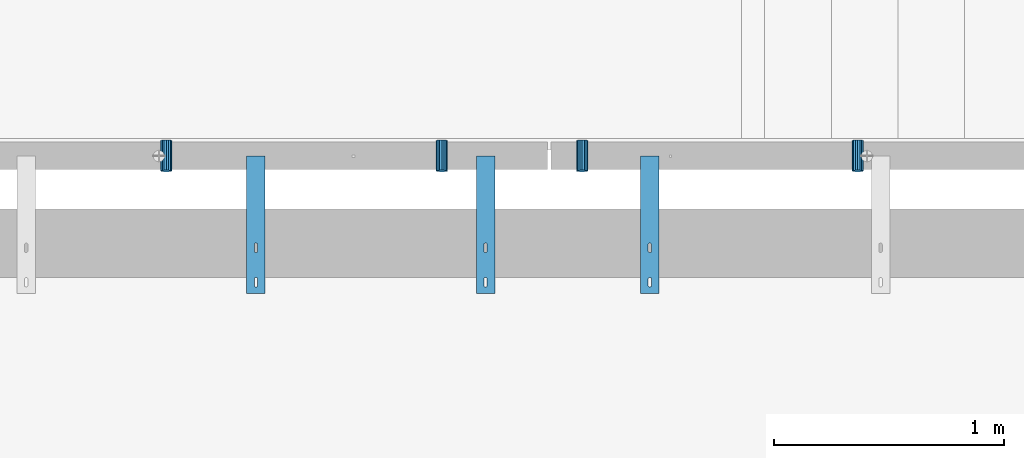
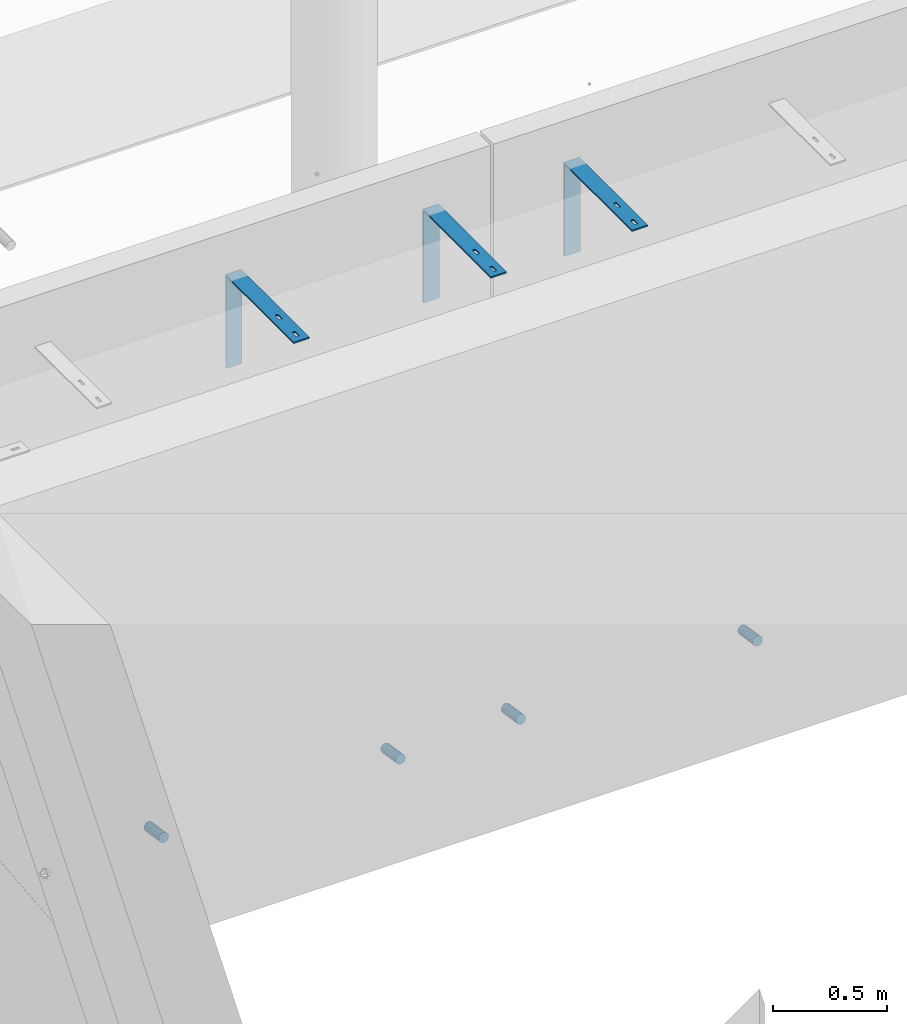
# One storey, part 101 of 264: 7 beams, 8 elements without a shape of their own.
"""IFC2X3 building model written with IfcOpenShell, lengths in millimetres."""

from ifc_helpers import new_model, si_unit, frame, origin_with_axes, place, context, subcontext, project, spatial, faceted_brep, material, type_object, element, aggregate, save


model = new_model("IFC2X3")

# Units and contexts
model_context = context("Model", 3, precision=1e-05, world=origin_with_axes())
body_context = subcontext(model_context, "Body", "Model", "MODEL_VIEW")
ifc_project = project(units=[si_unit("LENGTHUNIT", "METRE", prefix="MILLI"), si_unit("AREAUNIT", "SQUARE_METRE"), si_unit("VOLUMEUNIT", "CUBIC_METRE"), si_unit("MASSUNIT", "GRAM", prefix="KILO"), si_unit("TIMEUNIT", "SECOND"), si_unit("PLANEANGLEUNIT", "RADIAN"), si_unit("SOLIDANGLEUNIT", "STERADIAN"), si_unit("THERMODYNAMICTEMPERATUREUNIT", "DEGREE_CELSIUS"), si_unit("LUMINOUSINTENSITYUNIT", "LUMEN")], contexts=[model_context])

# Site, building, storey
site_placement = place(None, origin_with_axes())
site = spatial("IfcSite", under=ifc_project, at=site_placement, CompositionType="ELEMENT")
building_placement = place(site_placement, origin_with_axes())
building = spatial("IfcBuilding", under=site, at=building_placement, CompositionType="ELEMENT")
storey_placement = place(building_placement, origin_with_axes())
storey = spatial("IfcBuildingStorey", under=building, at=storey_placement, Name="K", CompositionType="ELEMENT", Elevation=0.0)

# Assemblies, beam
assembly_1_placement = place(storey_placement, origin_with_axes())
assembly_1 = element("IfcElementAssembly", 1, at=assembly_1_placement, inside=storey, AssemblyPlace="NOTDEFINED", PredefinedType="REINFORCEMENT_UNIT")
assembly_2_placement = place(assembly_1_placement, origin_with_axes())
assembly_2 = element("IfcElementAssembly", 2, at=assembly_2_placement, Name="Steel Assembly", AssemblyPlace="NOTDEFINED", PredefinedType="NOTDEFINED")
ifc_material_1 = material()
beam_type_1 = type_object("IfcBeamType", Name="D50", PredefinedType="NOTDEFINED")
beam_1_placement = place(assembly_2_placement, frame((12294.9999997536, 20794.388890547, 78614.7172983598), z_axis=(-1.0, 3.00000001838171e-08, 0.0), x_axis=(-5.60000020538061e-08, 0.988691934499859, -0.14996085707585)))
beam_1 = element("IfcBeam", 3, at=beam_1_placement, type_object=beam_type_1, material=ifc_material_1, ObjectType="D50", context=body_context, shape_type="Brep", body=[
    faceted_brep([(0.0, -25.0, 0.0), (-3.63797880709171e-12, -23.0969883127837, -9.56708580912891), (133.368135763521, -23.0969883127691, -9.56708580912709), (133.368135766923, -24.9999999999854, 1.81898940354586e-12), (-3.63797880709171e-12, -17.6776695296576, -17.6776695296649), (133.36813576064, -17.6776695296576, -17.677669529663), (-1.09139364212751e-11, -9.56708580913255, -23.0969883127837), (133.368135758712, -9.567085809118, -23.0969883127818), (-1.09139364212751e-11, 0.0, -25.0), (133.368135758034, 0.0, -25.0), (-1.09139364212751e-11, 9.56708580913255, -23.0969883127837), (133.36813575871, 9.56708580913255, -23.0969883127837), (-3.63797880709171e-12, 17.6776695296576, -17.6776695296649), (133.36813576064, 17.6776695296721, -17.677669529663), (-3.63797880709171e-12, 23.0969883127837, -9.56708580912891), (133.36813576352, 23.0969883127982, -9.56708580912709), (0.0, 25.0, 0.0), (133.368135766925, 25.0000000000146, -1.81898940354586e-12), (7.27595761418343e-12, 23.0969883127837, 9.56708580912891), (133.368135770323, 23.0969883127837, 9.56708580912709), (7.27595761418343e-12, 17.6776695296576, 17.6776695296649), (133.368135773204, 17.6776695296721, 17.6776695296649), (1.45519152283669e-11, 9.56708580913255, 23.0969883127837), (133.368135775132, 9.5670858091471, 23.0969883127837), (1.09139364212751e-11, 0.0, 25.0), (133.368135775807, 1.45519152283669e-11, 25.0), (1.45519152283669e-11, -9.56708580913255, 23.0969883127837), (133.368135775134, -9.56708580910345, 23.0969883127837), (7.27595761418343e-12, -17.6776695296576, 17.6776695296649), (133.368135773204, -17.6776695296721, 17.6776695296649), (7.27595761418343e-12, -23.0969883127837, 9.56708580912891), (133.368135770321, -23.0969883127691, 9.56708580912709)], [[[0, 1, 2, 3]], [[1, 4, 5, 2]], [[4, 6, 7, 5]], [[6, 8, 9, 7]], [[8, 10, 11, 9]], [[10, 12, 13, 11]], [[12, 14, 15, 13]], [[14, 16, 17, 15]], [[16, 18, 19, 17]], [[18, 20, 21, 19]], [[20, 22, 23, 21]], [[22, 24, 25, 23]], [[24, 26, 27, 25]], [[26, 28, 29, 27]], [[28, 30, 31, 29]], [[30, 0, 3, 31]], [[5, 7, 9, 11, 13, 15, 17, 19, 21, 23, 25, 27, 29, 31, 3, 2]], [[30, 28, 26, 24, 22, 20, 18, 16, 14, 12, 10, 8, 6, 4, 1, 0]]]),
])
aggregate(assembly_2, [beam_1])

# Assemblies, beams
assembly_3_placement = place(storey_placement, origin_with_axes())
assembly_3 = element("IfcElementAssembly", 4, at=assembly_3_placement, inside=storey, AssemblyPlace="NOTDEFINED", PredefinedType="REINFORCEMENT_UNIT")
assembly_4_placement = place(assembly_3_placement, origin_with_axes())
assembly_4 = element("IfcElementAssembly", 5, at=assembly_4_placement, Name="Steel Assembly", AssemblyPlace="NOTDEFINED", PredefinedType="NOTDEFINED")
beam_2_placement = place(assembly_4_placement, frame((9284.99999975361, 20794.388890547, 78614.7172983598), z_axis=(-1.0, 3.00000001838171e-08, 0.0), x_axis=(-5.60000020538061e-08, 0.988691934499859, -0.14996085707585)))
beam_2 = element("IfcBeam", 6, at=beam_2_placement, type_object=beam_type_1, material=ifc_material_1, ObjectType="D50", context=body_context, shape_type="Brep", body=[
    faceted_brep([(0.0, -25.0, 0.0), (-3.63797880709171e-12, -23.0969883127837, -9.56708580912891), (133.368135763521, -23.0969883127691, -9.56708580912709), (133.368135766923, -24.9999999999854, 1.81898940354586e-12), (-3.63797880709171e-12, -17.6776695296576, -17.6776695296649), (133.36813576064, -17.6776695296576, -17.677669529663), (-1.09139364212751e-11, -9.56708580913255, -23.0969883127837), (133.368135758712, -9.567085809118, -23.0969883127818), (-1.09139364212751e-11, 0.0, -25.0), (133.368135758034, 0.0, -25.0), (-1.09139364212751e-11, 9.56708580913255, -23.0969883127837), (133.36813575871, 9.56708580913255, -23.0969883127837), (-3.63797880709171e-12, 17.6776695296576, -17.6776695296649), (133.36813576064, 17.6776695296721, -17.677669529663), (-3.63797880709171e-12, 23.0969883127837, -9.56708580912891), (133.36813576352, 23.0969883127982, -9.56708580912709), (0.0, 25.0, 0.0), (133.368135766925, 25.0000000000146, -1.81898940354586e-12), (7.27595761418343e-12, 23.0969883127837, 9.56708580912891), (133.368135770323, 23.0969883127837, 9.56708580912709), (7.27595761418343e-12, 17.6776695296576, 17.6776695296649), (133.368135773204, 17.6776695296721, 17.6776695296649), (1.45519152283669e-11, 9.56708580913255, 23.0969883127837), (133.368135775132, 9.5670858091471, 23.0969883127837), (1.09139364212751e-11, 0.0, 25.0), (133.368135775807, 1.45519152283669e-11, 25.0), (1.45519152283669e-11, -9.56708580913255, 23.0969883127837), (133.368135775134, -9.56708580910345, 23.0969883127837), (7.27595761418343e-12, -17.6776695296576, 17.6776695296649), (133.368135773204, -17.6776695296721, 17.6776695296649), (7.27595761418343e-12, -23.0969883127837, 9.56708580912891), (133.368135770321, -23.0969883127691, 9.56708580912709)], [[[0, 1, 2, 3]], [[1, 4, 5, 2]], [[4, 6, 7, 5]], [[6, 8, 9, 7]], [[8, 10, 11, 9]], [[10, 12, 13, 11]], [[12, 14, 15, 13]], [[14, 16, 17, 15]], [[16, 18, 19, 17]], [[18, 20, 21, 19]], [[20, 22, 23, 21]], [[22, 24, 25, 23]], [[24, 26, 27, 25]], [[26, 28, 29, 27]], [[28, 30, 31, 29]], [[30, 0, 3, 31]], [[5, 7, 9, 11, 13, 15, 17, 19, 21, 23, 25, 27, 29, 31, 3, 2]], [[30, 28, 26, 24, 22, 20, 18, 16, 14, 12, 10, 8, 6, 4, 1, 0]]]),
])
aggregate(assembly_4, [beam_2])
assembly_5_placement = place(assembly_3_placement, origin_with_axes())
assembly_5 = element("IfcElementAssembly", 7, at=assembly_5_placement, Name="Steel Assembly", AssemblyPlace="NOTDEFINED", PredefinedType="NOTDEFINED")
beam_3_placement = place(assembly_5_placement, frame((10484.9999997536, 20794.388890547, 78614.7172983598), z_axis=(-1.0, 3.00000001838171e-08, 0.0), x_axis=(-5.60000020538061e-08, 0.988691934499859, -0.14996085707585)))
beam_3 = element("IfcBeam", 8, at=beam_3_placement, type_object=beam_type_1, material=ifc_material_1, ObjectType="D50", context=body_context, shape_type="Brep", body=[
    faceted_brep([(0.0, -25.0, 0.0), (-3.63797880709171e-12, -23.0969883127837, -9.56708580912891), (133.368135763521, -23.0969883127691, -9.56708580912709), (133.368135766923, -24.9999999999854, 1.81898940354586e-12), (-3.63797880709171e-12, -17.6776695296576, -17.6776695296649), (133.36813576064, -17.6776695296576, -17.677669529663), (-1.09139364212751e-11, -9.56708580913255, -23.0969883127837), (133.368135758712, -9.567085809118, -23.0969883127818), (-1.09139364212751e-11, 0.0, -25.0), (133.368135758034, 0.0, -25.0), (-1.09139364212751e-11, 9.56708580913255, -23.0969883127837), (133.36813575871, 9.56708580913255, -23.0969883127837), (-3.63797880709171e-12, 17.6776695296576, -17.6776695296649), (133.36813576064, 17.6776695296721, -17.677669529663), (-3.63797880709171e-12, 23.0969883127837, -9.56708580912891), (133.36813576352, 23.0969883127982, -9.56708580912709), (0.0, 25.0, 0.0), (133.368135766925, 25.0000000000146, -1.81898940354586e-12), (7.27595761418343e-12, 23.0969883127837, 9.56708580912891), (133.368135770323, 23.0969883127837, 9.56708580912709), (7.27595761418343e-12, 17.6776695296576, 17.6776695296649), (133.368135773204, 17.6776695296721, 17.6776695296649), (1.45519152283669e-11, 9.56708580913255, 23.0969883127837), (133.368135775132, 9.5670858091471, 23.0969883127837), (1.09139364212751e-11, 0.0, 25.0), (133.368135775807, 1.45519152283669e-11, 25.0), (1.45519152283669e-11, -9.56708580913255, 23.0969883127837), (133.368135775134, -9.56708580910345, 23.0969883127837), (7.27595761418343e-12, -17.6776695296576, 17.6776695296649), (133.368135773204, -17.6776695296721, 17.6776695296649), (7.27595761418343e-12, -23.0969883127837, 9.56708580912891), (133.368135770321, -23.0969883127691, 9.56708580912709)], [[[0, 1, 2, 3]], [[1, 4, 5, 2]], [[4, 6, 7, 5]], [[6, 8, 9, 7]], [[8, 10, 11, 9]], [[10, 12, 13, 11]], [[12, 14, 15, 13]], [[14, 16, 17, 15]], [[16, 18, 19, 17]], [[18, 20, 21, 19]], [[20, 22, 23, 21]], [[22, 24, 25, 23]], [[24, 26, 27, 25]], [[26, 28, 29, 27]], [[28, 30, 31, 29]], [[30, 0, 3, 31]], [[5, 7, 9, 11, 13, 15, 17, 19, 21, 23, 25, 27, 29, 31, 3, 2]], [[30, 28, 26, 24, 22, 20, 18, 16, 14, 12, 10, 8, 6, 4, 1, 0]]]),
])
aggregate(assembly_5, [beam_3])

# Beam
beam_4_placement = place(assembly_1_placement, frame((11094.9999997536, 20794.388890547, 78614.7172983598), z_axis=(-1.0, 3.00000001838171e-08, 0.0), x_axis=(-5.60000020538061e-08, 0.988691934499859, -0.14996085707585)))
beam_4 = element("IfcBeam", 9, at=beam_4_placement, type_object=beam_type_1, material=ifc_material_1, ObjectType="D50", context=body_context, shape_type="Brep", body=[
    faceted_brep([(0.0, -25.0, 0.0), (-3.63797880709171e-12, -23.0969883127837, -9.56708580912891), (133.368135763521, -23.0969883127691, -9.56708580912709), (133.368135766923, -24.9999999999854, 1.81898940354586e-12), (-3.63797880709171e-12, -17.6776695296576, -17.6776695296649), (133.36813576064, -17.6776695296576, -17.677669529663), (-1.09139364212751e-11, -9.56708580913255, -23.0969883127837), (133.368135758712, -9.567085809118, -23.0969883127818), (-1.09139364212751e-11, 0.0, -25.0), (133.368135758034, 0.0, -25.0), (-1.09139364212751e-11, 9.56708580913255, -23.0969883127837), (133.36813575871, 9.56708580913255, -23.0969883127837), (-3.63797880709171e-12, 17.6776695296576, -17.6776695296649), (133.36813576064, 17.6776695296721, -17.677669529663), (-3.63797880709171e-12, 23.0969883127837, -9.56708580912891), (133.36813576352, 23.0969883127982, -9.56708580912709), (0.0, 25.0, 0.0), (133.368135766925, 25.0000000000146, -1.81898940354586e-12), (7.27595761418343e-12, 23.0969883127837, 9.56708580912891), (133.368135770323, 23.0969883127837, 9.56708580912709), (7.27595761418343e-12, 17.6776695296576, 17.6776695296649), (133.368135773204, 17.6776695296721, 17.6776695296649), (1.45519152283669e-11, 9.56708580913255, 23.0969883127837), (133.368135775132, 9.5670858091471, 23.0969883127837), (1.09139364212751e-11, 0.0, 25.0), (133.368135775807, 1.45519152283669e-11, 25.0), (1.45519152283669e-11, -9.56708580913255, 23.0969883127837), (133.368135775134, -9.56708580910345, 23.0969883127837), (7.27595761418343e-12, -17.6776695296576, 17.6776695296649), (133.368135773204, -17.6776695296721, 17.6776695296649), (7.27595761418343e-12, -23.0969883127837, 9.56708580912891), (133.368135770321, -23.0969883127691, 9.56708580912709)], [[[0, 1, 2, 3]], [[1, 4, 5, 2]], [[4, 6, 7, 5]], [[6, 8, 9, 7]], [[8, 10, 11, 9]], [[10, 12, 13, 11]], [[12, 14, 15, 13]], [[14, 16, 17, 15]], [[16, 18, 19, 17]], [[18, 20, 21, 19]], [[20, 22, 23, 21]], [[22, 24, 25, 23]], [[24, 26, 27, 25]], [[26, 28, 29, 27]], [[28, 30, 31, 29]], [[30, 0, 3, 31]], [[5, 7, 9, 11, 13, 15, 17, 19, 21, 23, 25, 27, 29, 31, 3, 2]], [[30, 28, 26, 24, 22, 20, 18, 16, 14, 12, 10, 8, 6, 4, 1, 0]]]),
])

# Assembly
assembly_6_placement = place(assembly_1_placement, origin_with_axes())
assembly_6 = element("IfcElementAssembly", 10, at=assembly_6_placement, Name="Steel Assembly", AssemblyPlace="NOTDEFINED", PredefinedType="RIGID_FRAME")

aggregate(assembly_1, [assembly_2, assembly_6, beam_4])

# Beam
ifc_material_2 = material(Name="STEEL/1.4301")
beam_type_2 = type_object("IfcBeamType", PredefinedType="NOTDEFINED")
beam_5_placement = place(assembly_6_placement, frame((11350.0, 20560.0, 81220.0), z_axis=(0.0, -1.0, 0.0), x_axis=(1.0, 0.0, 0.0)))
beam_5 = element("IfcBeam", 11, at=beam_5_placement, type_object=beam_type_2, material=ifc_material_2, Name="RST", context=body_context, shape_type="Brep", body=[
    faceted_brep([(46.9999999999854, 250.0, 84.9999999999964), (46.9999999999854, 242.0, 84.9999999999964), (46.9999999999854, 242.0, 114.999999999996), (46.9999999999854, 250.0, 114.999999999996), (46.7552825814619, 242.0, 116.545084971873), (46.7552825814619, 250.0, 116.545084971873), (46.04508497186, 242.0, 117.93892626146), (46.04508497186, 250.0, 117.93892626146), (44.9389262614477, 242.0, 119.045084971873), (44.9389262614477, 250.0, 119.045084971873), (43.54508497186, 242.0, 119.755282581471), (43.54508497186, 250.0, 119.755282581471), (41.9999999999854, 242.0, 119.999999999996), (41.9999999999854, 250.0, 119.999999999996), (37.9999999999854, 242.0, 119.999999999996), (37.9999999999854, 250.0, 119.999999999996), (36.4549150281109, 242.0, 119.755282581471), (36.4549150281109, 250.0, 119.755282581471), (35.0610737385232, 242.0, 119.045084971873), (35.0610737385232, 250.0, 119.045084971873), (33.9549150281109, 242.0, 117.93892626146), (33.9549150281109, 250.0, 117.93892626146), (33.244717418509, 242.0, 116.545084971873), (33.244717418509, 250.0, 116.545084971873), (32.9999999999854, 242.0, 114.999999999996), (32.9999999999854, 250.0, 114.999999999996), (32.9999999999854, 242.0, 84.9999999999964), (32.9999999999854, 250.0, 84.9999999999964), (33.244717418509, 242.0, 83.4549150281237), (33.244717418509, 250.0, 83.4549150281237), (33.9549150281109, 242.0, 82.0610737385359), (33.9549150281109, 250.0, 82.0610737385359), (35.0610737385232, 242.0, 80.9549150281237), (35.0610737385232, 250.0, 80.9549150281237), (36.4549150281109, 242.0, 80.2447174185218), (36.4549150281109, 250.0, 80.2447174185218), (37.9999999999854, 242.0, 79.9999999999964), (37.9999999999854, 250.0, 79.9999999999964), (41.9999999999854, 242.0, 79.9999999999964), (41.9999999999854, 250.0, 79.9999999999964), (43.54508497186, 242.0, 80.2447174185218), (43.54508497186, 250.0, 80.2447174185218), (44.9389262614477, 242.0, 80.9549150281237), (44.9389262614477, 250.0, 80.9549150281237), (46.04508497186, 242.0, 82.0610737385359), (46.04508497186, 250.0, 82.0610737385359), (46.7552825814619, 242.0, 83.4549150281237), (46.7552825814619, 250.0, 83.4549150281237), (0.0, -250.0, -292.0), (0.0, -250.0, -300.0), (80.0, -250.0, -300.0), (80.0, -250.0, -292.0), (0.0, 242.0, -292.0), (80.0, 242.0, -292.0), (0.0, 250.0, 300.0), (0.0, 242.0, 300.0), (80.0, 242.0, 300.0), (80.0, 250.0, 300.0), (0.0, 250.0, -300.0), (80.0, 250.0, -300.0), (46.9999999999854, 250.0, 264.999999999996), (46.7552825814619, 250.0, 266.545084971873), (46.04508497186, 250.0, 267.93892626146), (44.9389262614477, 250.0, 269.045084971873), (43.54508497186, 250.0, 269.755282581471), (41.9999999999854, 250.0, 269.999999999996), (37.9999999999854, 250.0, 269.999999999996), (36.4549150281109, 250.0, 269.755282581471), (35.0610737385232, 250.0, 269.045084971873), (33.9549150281109, 250.0, 267.93892626146), (33.244717418509, 250.0, 266.545084971873), (32.9999999999854, 250.0, 264.999999999996), (32.9999999999854, 250.0, 234.999999999996), (33.244717418509, 250.0, 233.454915028124), (33.9549150281109, 250.0, 232.061073738536), (35.0610737385232, 250.0, 230.954915028124), (36.4549150281109, 250.0, 230.244717418522), (37.9999999999854, 250.0, 229.999999999996), (41.9999999999854, 250.0, 229.999999999996), (43.54508497186, 250.0, 230.244717418522), (44.9389262614477, 250.0, 230.954915028124), (46.04508497186, 250.0, 232.061073738536), (46.7552825814619, 250.0, 233.454915028124), (46.9999999999854, 250.0, 234.999999999996), (44.9389262614477, 242.0, 230.954915028124), (46.04508497186, 242.0, 232.061073738536), (43.54508497186, 242.0, 230.244717418522), (41.9999999999854, 242.0, 229.999999999996), (37.9999999999854, 242.0, 229.999999999996), (36.4549150281109, 242.0, 230.244717418522), (35.0610737385232, 242.0, 230.954915028124), (33.9549150281109, 242.0, 232.061073738536), (33.244717418509, 242.0, 233.454915028124), (32.9999999999854, 242.0, 234.999999999996), (32.9999999999854, 242.0, 264.999999999996), (33.244717418509, 242.0, 266.545084971873), (33.9549150281109, 242.0, 267.93892626146), (35.0610737385232, 242.0, 269.045084971873), (36.4549150281109, 242.0, 269.755282581471), (37.9999999999854, 242.0, 269.999999999996), (41.9999999999854, 242.0, 269.999999999996), (43.54508497186, 242.0, 269.755282581471), (44.9389262614477, 242.0, 269.045084971873), (46.04508497186, 242.0, 267.93892626146), (46.7552825814619, 242.0, 266.545084971873), (46.9999999999854, 242.0, 264.999999999996), (46.9999999999854, 242.0, 234.999999999996), (46.7552825814619, 242.0, 233.454915028124)], [[[0, 1, 2, 3]], [[3, 2, 4, 5]], [[5, 4, 6, 7]], [[7, 6, 8, 9]], [[9, 8, 10, 11]], [[11, 10, 12, 13]], [[13, 12, 14, 15]], [[15, 14, 16, 17]], [[17, 16, 18, 19]], [[19, 18, 20, 21]], [[21, 20, 22, 23]], [[23, 22, 24, 25]], [[25, 24, 26, 27]], [[27, 26, 28, 29]], [[29, 28, 30, 31]], [[31, 30, 32, 33]], [[33, 32, 34, 35]], [[35, 34, 36, 37]], [[37, 36, 38, 39]], [[39, 38, 40, 41]], [[41, 40, 42, 43]], [[43, 42, 44, 45]], [[45, 44, 46, 47]], [[47, 46, 1, 0]], [[48, 49, 50, 51]], [[52, 48, 51, 53]], [[54, 55, 56, 57]], [[49, 48, 52, 55, 54, 58]], [[49, 58, 59, 50]], [[56, 53, 51, 50, 59, 57]], [[58, 54, 57, 59], [3, 5, 7, 9, 11, 13, 15, 17, 19, 21, 23, 25, 27, 29, 31, 33, 35, 37, 39, 41, 43, 45, 47, 0], [60, 61, 62, 63, 64, 65, 66, 67, 68, 69, 70, 71, 72, 73, 74, 75, 76, 77, 78, 79, 80, 81, 82, 83]], [[80, 84, 85, 81]], [[79, 86, 84, 80]], [[78, 87, 86, 79]], [[77, 88, 87, 78]], [[76, 89, 88, 77]], [[75, 90, 89, 76]], [[74, 91, 90, 75]], [[73, 92, 91, 74]], [[72, 93, 92, 73]], [[71, 94, 93, 72]], [[70, 95, 94, 71]], [[69, 96, 95, 70]], [[68, 97, 96, 69]], [[67, 98, 97, 68]], [[66, 99, 98, 67]], [[65, 100, 99, 66]], [[64, 101, 100, 65]], [[63, 102, 101, 64]], [[62, 103, 102, 63]], [[61, 104, 103, 62]], [[60, 105, 104, 61]], [[83, 106, 105, 60]], [[82, 107, 106, 83]], [[81, 85, 107, 82]], [[55, 52, 53, 56], [42, 40, 38, 36, 34, 32, 30, 28, 26, 24, 22, 20, 18, 16, 14, 12, 10, 8, 6, 4, 2, 1, 46, 44], [84, 86, 87, 88, 89, 90, 91, 92, 93, 94, 95, 96, 97, 98, 99, 100, 101, 102, 103, 104, 105, 106, 107, 85]]]),
])

aggregate(assembly_6, [beam_5])

# Assembly, beam
assembly_7_placement = place(assembly_3_placement, origin_with_axes())
assembly_7 = element("IfcElementAssembly", 12, at=assembly_7_placement, Name="Steel Assembly", AssemblyPlace="NOTDEFINED", PredefinedType="RIGID_FRAME")
beam_6_placement = place(assembly_7_placement, frame((10635.0, 20560.0, 81220.0), z_axis=(0.0, -1.0, 0.0), x_axis=(1.0, 0.0, 0.0)))
beam_6 = element("IfcBeam", 13, at=beam_6_placement, type_object=beam_type_2, material=ifc_material_2, Name="RST", context=body_context, shape_type="Brep", body=[
    faceted_brep([(46.9999999999854, 250.0, 84.9999999999964), (46.9999999999854, 242.0, 84.9999999999964), (46.9999999999854, 242.0, 114.999999999996), (46.9999999999854, 250.0, 114.999999999996), (46.7552825814619, 242.0, 116.545084971873), (46.7552825814619, 250.0, 116.545084971873), (46.04508497186, 242.0, 117.93892626146), (46.04508497186, 250.0, 117.93892626146), (44.9389262614477, 242.0, 119.045084971873), (44.9389262614477, 250.0, 119.045084971873), (43.54508497186, 242.0, 119.755282581471), (43.54508497186, 250.0, 119.755282581471), (41.9999999999854, 242.0, 119.999999999996), (41.9999999999854, 250.0, 119.999999999996), (37.9999999999854, 242.0, 119.999999999996), (37.9999999999854, 250.0, 119.999999999996), (36.4549150281109, 242.0, 119.755282581471), (36.4549150281109, 250.0, 119.755282581471), (35.0610737385232, 242.0, 119.045084971873), (35.0610737385232, 250.0, 119.045084971873), (33.9549150281109, 242.0, 117.93892626146), (33.9549150281109, 250.0, 117.93892626146), (33.244717418509, 242.0, 116.545084971873), (33.244717418509, 250.0, 116.545084971873), (32.9999999999854, 242.0, 114.999999999996), (32.9999999999854, 250.0, 114.999999999996), (32.9999999999854, 242.0, 84.9999999999964), (32.9999999999854, 250.0, 84.9999999999964), (33.244717418509, 242.0, 83.4549150281237), (33.244717418509, 250.0, 83.4549150281237), (33.9549150281109, 242.0, 82.0610737385359), (33.9549150281109, 250.0, 82.0610737385359), (35.0610737385232, 242.0, 80.9549150281237), (35.0610737385232, 250.0, 80.9549150281237), (36.4549150281109, 242.0, 80.2447174185218), (36.4549150281109, 250.0, 80.2447174185218), (37.9999999999854, 242.0, 79.9999999999964), (37.9999999999854, 250.0, 79.9999999999964), (41.9999999999854, 242.0, 79.9999999999964), (41.9999999999854, 250.0, 79.9999999999964), (43.54508497186, 242.0, 80.2447174185218), (43.54508497186, 250.0, 80.2447174185218), (44.9389262614477, 242.0, 80.9549150281237), (44.9389262614477, 250.0, 80.9549150281237), (46.04508497186, 242.0, 82.0610737385359), (46.04508497186, 250.0, 82.0610737385359), (46.7552825814619, 242.0, 83.4549150281237), (46.7552825814619, 250.0, 83.4549150281237), (0.0, -250.0, -292.0), (0.0, -250.0, -300.0), (80.0, -250.0, -300.0), (80.0, -250.0, -292.0), (0.0, 242.0, -292.0), (80.0, 242.0, -292.0), (0.0, 250.0, 300.0), (0.0, 242.0, 300.0), (80.0, 242.0, 300.0), (80.0, 250.0, 300.0), (0.0, 250.0, -300.0), (80.0, 250.0, -300.0), (46.9999999999854, 250.0, 264.999999999996), (46.7552825814619, 250.0, 266.545084971873), (46.04508497186, 250.0, 267.93892626146), (44.9389262614477, 250.0, 269.045084971873), (43.54508497186, 250.0, 269.755282581471), (41.9999999999854, 250.0, 269.999999999996), (37.9999999999854, 250.0, 269.999999999996), (36.4549150281109, 250.0, 269.755282581471), (35.0610737385232, 250.0, 269.045084971873), (33.9549150281109, 250.0, 267.93892626146), (33.244717418509, 250.0, 266.545084971873), (32.9999999999854, 250.0, 264.999999999996), (32.9999999999854, 250.0, 234.999999999996), (33.244717418509, 250.0, 233.454915028124), (33.9549150281109, 250.0, 232.061073738536), (35.0610737385232, 250.0, 230.954915028124), (36.4549150281109, 250.0, 230.244717418522), (37.9999999999854, 250.0, 229.999999999996), (41.9999999999854, 250.0, 229.999999999996), (43.54508497186, 250.0, 230.244717418522), (44.9389262614477, 250.0, 230.954915028124), (46.04508497186, 250.0, 232.061073738536), (46.7552825814619, 250.0, 233.454915028124), (46.9999999999854, 250.0, 234.999999999996), (44.9389262614477, 242.0, 230.954915028124), (46.04508497186, 242.0, 232.061073738536), (43.54508497186, 242.0, 230.244717418522), (41.9999999999854, 242.0, 229.999999999996), (37.9999999999854, 242.0, 229.999999999996), (36.4549150281109, 242.0, 230.244717418522), (35.0610737385232, 242.0, 230.954915028124), (33.9549150281109, 242.0, 232.061073738536), (33.244717418509, 242.0, 233.454915028124), (32.9999999999854, 242.0, 234.999999999996), (32.9999999999854, 242.0, 264.999999999996), (33.244717418509, 242.0, 266.545084971873), (33.9549150281109, 242.0, 267.93892626146), (35.0610737385232, 242.0, 269.045084971873), (36.4549150281109, 242.0, 269.755282581471), (37.9999999999854, 242.0, 269.999999999996), (41.9999999999854, 242.0, 269.999999999996), (43.54508497186, 242.0, 269.755282581471), (44.9389262614477, 242.0, 269.045084971873), (46.04508497186, 242.0, 267.93892626146), (46.7552825814619, 242.0, 266.545084971873), (46.9999999999854, 242.0, 264.999999999996), (46.9999999999854, 242.0, 234.999999999996), (46.7552825814619, 242.0, 233.454915028124)], [[[0, 1, 2, 3]], [[3, 2, 4, 5]], [[5, 4, 6, 7]], [[7, 6, 8, 9]], [[9, 8, 10, 11]], [[11, 10, 12, 13]], [[13, 12, 14, 15]], [[15, 14, 16, 17]], [[17, 16, 18, 19]], [[19, 18, 20, 21]], [[21, 20, 22, 23]], [[23, 22, 24, 25]], [[25, 24, 26, 27]], [[27, 26, 28, 29]], [[29, 28, 30, 31]], [[31, 30, 32, 33]], [[33, 32, 34, 35]], [[35, 34, 36, 37]], [[37, 36, 38, 39]], [[39, 38, 40, 41]], [[41, 40, 42, 43]], [[43, 42, 44, 45]], [[45, 44, 46, 47]], [[47, 46, 1, 0]], [[48, 49, 50, 51]], [[52, 48, 51, 53]], [[54, 55, 56, 57]], [[49, 48, 52, 55, 54, 58]], [[49, 58, 59, 50]], [[56, 53, 51, 50, 59, 57]], [[58, 54, 57, 59], [3, 5, 7, 9, 11, 13, 15, 17, 19, 21, 23, 25, 27, 29, 31, 33, 35, 37, 39, 41, 43, 45, 47, 0], [60, 61, 62, 63, 64, 65, 66, 67, 68, 69, 70, 71, 72, 73, 74, 75, 76, 77, 78, 79, 80, 81, 82, 83]], [[80, 84, 85, 81]], [[79, 86, 84, 80]], [[78, 87, 86, 79]], [[77, 88, 87, 78]], [[76, 89, 88, 77]], [[75, 90, 89, 76]], [[74, 91, 90, 75]], [[73, 92, 91, 74]], [[72, 93, 92, 73]], [[71, 94, 93, 72]], [[70, 95, 94, 71]], [[69, 96, 95, 70]], [[68, 97, 96, 69]], [[67, 98, 97, 68]], [[66, 99, 98, 67]], [[65, 100, 99, 66]], [[64, 101, 100, 65]], [[63, 102, 101, 64]], [[62, 103, 102, 63]], [[61, 104, 103, 62]], [[60, 105, 104, 61]], [[83, 106, 105, 60]], [[82, 107, 106, 83]], [[81, 85, 107, 82]], [[55, 52, 53, 56], [42, 40, 38, 36, 34, 32, 30, 28, 26, 24, 22, 20, 18, 16, 14, 12, 10, 8, 6, 4, 2, 1, 46, 44], [84, 86, 87, 88, 89, 90, 91, 92, 93, 94, 95, 96, 97, 98, 99, 100, 101, 102, 103, 104, 105, 106, 107, 85]]]),
])
aggregate(assembly_7, [beam_6])

# Assembly
assembly_8_placement = place(assembly_3_placement, origin_with_axes())
assembly_8 = element("IfcElementAssembly", 14, at=assembly_8_placement, Name="Steel Assembly", AssemblyPlace="NOTDEFINED", PredefinedType="RIGID_FRAME")

aggregate(assembly_3, [assembly_7, assembly_8, assembly_4, assembly_5])

# Beam
beam_7_placement = place(assembly_8_placement, frame((9635.0, 20560.0, 81220.0), z_axis=(0.0, -1.0, 0.0), x_axis=(1.0, 0.0, 0.0)))
beam_7 = element("IfcBeam", 15, at=beam_7_placement, type_object=beam_type_2, material=ifc_material_2, Name="RST", context=body_context, shape_type="Brep", body=[
    faceted_brep([(46.9999999999854, 250.0, 84.9999999999964), (46.9999999999854, 242.0, 84.9999999999964), (46.9999999999854, 242.0, 114.999999999996), (46.9999999999854, 250.0, 114.999999999996), (46.7552825814619, 242.0, 116.545084971873), (46.7552825814619, 250.0, 116.545084971873), (46.04508497186, 242.0, 117.93892626146), (46.04508497186, 250.0, 117.93892626146), (44.9389262614477, 242.0, 119.045084971873), (44.9389262614477, 250.0, 119.045084971873), (43.54508497186, 242.0, 119.755282581471), (43.54508497186, 250.0, 119.755282581471), (41.9999999999854, 242.0, 119.999999999996), (41.9999999999854, 250.0, 119.999999999996), (37.9999999999854, 242.0, 119.999999999996), (37.9999999999854, 250.0, 119.999999999996), (36.4549150281109, 242.0, 119.755282581471), (36.4549150281109, 250.0, 119.755282581471), (35.0610737385232, 242.0, 119.045084971873), (35.0610737385232, 250.0, 119.045084971873), (33.9549150281109, 242.0, 117.93892626146), (33.9549150281109, 250.0, 117.93892626146), (33.244717418509, 242.0, 116.545084971873), (33.244717418509, 250.0, 116.545084971873), (32.9999999999854, 242.0, 114.999999999996), (32.9999999999854, 250.0, 114.999999999996), (32.9999999999854, 242.0, 84.9999999999964), (32.9999999999854, 250.0, 84.9999999999964), (33.244717418509, 242.0, 83.4549150281237), (33.244717418509, 250.0, 83.4549150281237), (33.9549150281109, 242.0, 82.0610737385359), (33.9549150281109, 250.0, 82.0610737385359), (35.0610737385232, 242.0, 80.9549150281237), (35.0610737385232, 250.0, 80.9549150281237), (36.4549150281109, 242.0, 80.2447174185218), (36.4549150281109, 250.0, 80.2447174185218), (37.9999999999854, 242.0, 79.9999999999964), (37.9999999999854, 250.0, 79.9999999999964), (41.9999999999854, 242.0, 79.9999999999964), (41.9999999999854, 250.0, 79.9999999999964), (43.54508497186, 242.0, 80.2447174185218), (43.54508497186, 250.0, 80.2447174185218), (44.9389262614477, 242.0, 80.9549150281237), (44.9389262614477, 250.0, 80.9549150281237), (46.04508497186, 242.0, 82.0610737385359), (46.04508497186, 250.0, 82.0610737385359), (46.7552825814619, 242.0, 83.4549150281237), (46.7552825814619, 250.0, 83.4549150281237), (0.0, -250.0, -292.0), (0.0, -250.0, -300.0), (80.0, -250.0, -300.0), (80.0, -250.0, -292.0), (0.0, 242.0, -292.0), (80.0, 242.0, -292.0), (0.0, 250.0, 300.0), (0.0, 242.0, 300.0), (80.0, 242.0, 300.0), (80.0, 250.0, 300.0), (0.0, 250.0, -300.0), (80.0, 250.0, -300.0), (46.9999999999854, 250.0, 264.999999999996), (46.7552825814619, 250.0, 266.545084971873), (46.04508497186, 250.0, 267.93892626146), (44.9389262614477, 250.0, 269.045084971873), (43.54508497186, 250.0, 269.755282581471), (41.9999999999854, 250.0, 269.999999999996), (37.9999999999854, 250.0, 269.999999999996), (36.4549150281109, 250.0, 269.755282581471), (35.0610737385232, 250.0, 269.045084971873), (33.9549150281109, 250.0, 267.93892626146), (33.244717418509, 250.0, 266.545084971873), (32.9999999999854, 250.0, 264.999999999996), (32.9999999999854, 250.0, 234.999999999996), (33.244717418509, 250.0, 233.454915028124), (33.9549150281109, 250.0, 232.061073738536), (35.0610737385232, 250.0, 230.954915028124), (36.4549150281109, 250.0, 230.244717418522), (37.9999999999854, 250.0, 229.999999999996), (41.9999999999854, 250.0, 229.999999999996), (43.54508497186, 250.0, 230.244717418522), (44.9389262614477, 250.0, 230.954915028124), (46.04508497186, 250.0, 232.061073738536), (46.7552825814619, 250.0, 233.454915028124), (46.9999999999854, 250.0, 234.999999999996), (44.9389262614477, 242.0, 230.954915028124), (46.04508497186, 242.0, 232.061073738536), (43.54508497186, 242.0, 230.244717418522), (41.9999999999854, 242.0, 229.999999999996), (37.9999999999854, 242.0, 229.999999999996), (36.4549150281109, 242.0, 230.244717418522), (35.0610737385232, 242.0, 230.954915028124), (33.9549150281109, 242.0, 232.061073738536), (33.244717418509, 242.0, 233.454915028124), (32.9999999999854, 242.0, 234.999999999996), (32.9999999999854, 242.0, 264.999999999996), (33.244717418509, 242.0, 266.545084971873), (33.9549150281109, 242.0, 267.93892626146), (35.0610737385232, 242.0, 269.045084971873), (36.4549150281109, 242.0, 269.755282581471), (37.9999999999854, 242.0, 269.999999999996), (41.9999999999854, 242.0, 269.999999999996), (43.54508497186, 242.0, 269.755282581471), (44.9389262614477, 242.0, 269.045084971873), (46.04508497186, 242.0, 267.93892626146), (46.7552825814619, 242.0, 266.545084971873), (46.9999999999854, 242.0, 264.999999999996), (46.9999999999854, 242.0, 234.999999999996), (46.7552825814619, 242.0, 233.454915028124)], [[[0, 1, 2, 3]], [[3, 2, 4, 5]], [[5, 4, 6, 7]], [[7, 6, 8, 9]], [[9, 8, 10, 11]], [[11, 10, 12, 13]], [[13, 12, 14, 15]], [[15, 14, 16, 17]], [[17, 16, 18, 19]], [[19, 18, 20, 21]], [[21, 20, 22, 23]], [[23, 22, 24, 25]], [[25, 24, 26, 27]], [[27, 26, 28, 29]], [[29, 28, 30, 31]], [[31, 30, 32, 33]], [[33, 32, 34, 35]], [[35, 34, 36, 37]], [[37, 36, 38, 39]], [[39, 38, 40, 41]], [[41, 40, 42, 43]], [[43, 42, 44, 45]], [[45, 44, 46, 47]], [[47, 46, 1, 0]], [[48, 49, 50, 51]], [[52, 48, 51, 53]], [[54, 55, 56, 57]], [[49, 48, 52, 55, 54, 58]], [[49, 58, 59, 50]], [[56, 53, 51, 50, 59, 57]], [[58, 54, 57, 59], [3, 5, 7, 9, 11, 13, 15, 17, 19, 21, 23, 25, 27, 29, 31, 33, 35, 37, 39, 41, 43, 45, 47, 0], [60, 61, 62, 63, 64, 65, 66, 67, 68, 69, 70, 71, 72, 73, 74, 75, 76, 77, 78, 79, 80, 81, 82, 83]], [[80, 84, 85, 81]], [[79, 86, 84, 80]], [[78, 87, 86, 79]], [[77, 88, 87, 78]], [[76, 89, 88, 77]], [[75, 90, 89, 76]], [[74, 91, 90, 75]], [[73, 92, 91, 74]], [[72, 93, 92, 73]], [[71, 94, 93, 72]], [[70, 95, 94, 71]], [[69, 96, 95, 70]], [[68, 97, 96, 69]], [[67, 98, 97, 68]], [[66, 99, 98, 67]], [[65, 100, 99, 66]], [[64, 101, 100, 65]], [[63, 102, 101, 64]], [[62, 103, 102, 63]], [[61, 104, 103, 62]], [[60, 105, 104, 61]], [[83, 106, 105, 60]], [[82, 107, 106, 83]], [[81, 85, 107, 82]], [[55, 52, 53, 56], [42, 40, 38, 36, 34, 32, 30, 28, 26, 24, 22, 20, 18, 16, 14, 12, 10, 8, 6, 4, 2, 1, 46, 44], [84, 86, 87, 88, 89, 90, 91, 92, 93, 94, 95, 96, 97, 98, 99, 100, 101, 102, 103, 104, 105, 106, 107, 85]]]),
])

aggregate(assembly_8, [beam_7])

save(model, "model.ifc")
